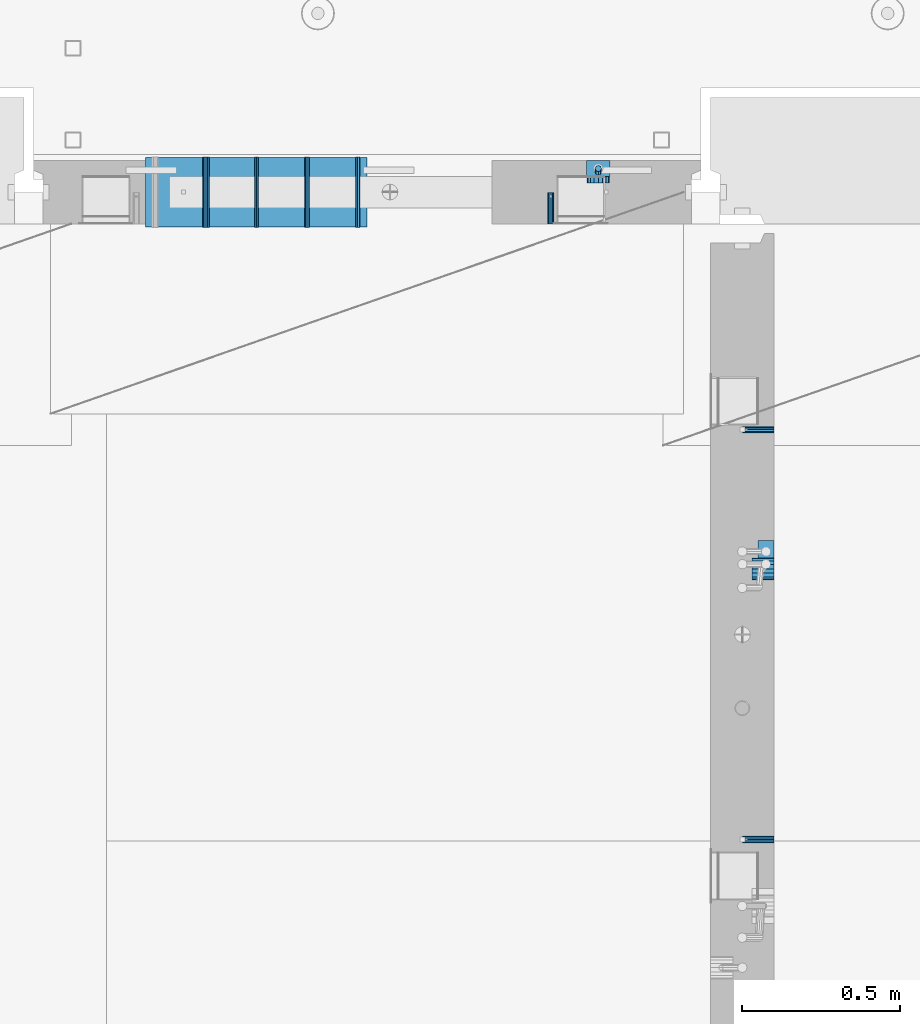
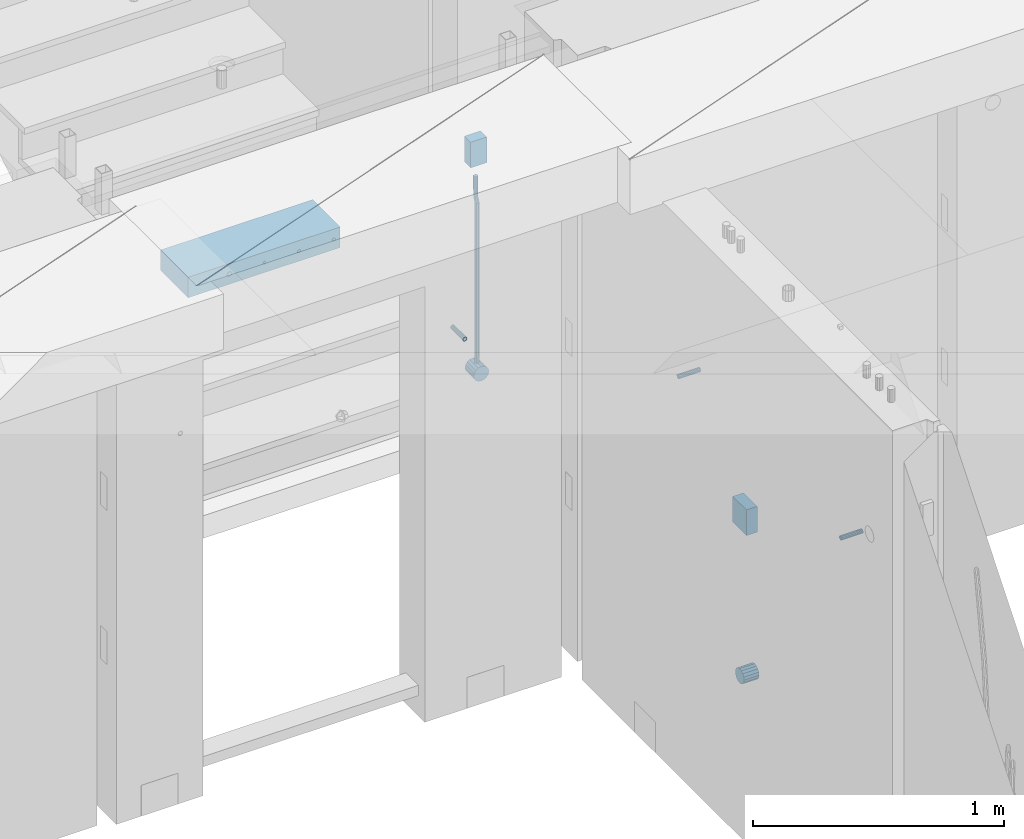
# One storey, part 149 of 350: 13 beams, 5 elements without a shape of their own.
"""IFC2X3 building model written with IfcOpenShell, lengths in millimetres."""

from ifc_helpers import new_model, si_unit, frame, origin_with_axes, place, context, subcontext, project, spatial, faceted_brep, material, type_object, element, aggregate, save


model = new_model("IFC2X3")

# Units and contexts
model_context = context("Model", 3, precision=1e-05, world=origin_with_axes())
body_context = subcontext(model_context, "Body", "Model", "MODEL_VIEW")
ifc_project = project(units=[si_unit("LENGTHUNIT", "METRE", prefix="MILLI"), si_unit("AREAUNIT", "SQUARE_METRE"), si_unit("VOLUMEUNIT", "CUBIC_METRE"), si_unit("MASSUNIT", "GRAM", prefix="KILO"), si_unit("TIMEUNIT", "SECOND"), si_unit("PLANEANGLEUNIT", "RADIAN"), si_unit("SOLIDANGLEUNIT", "STERADIAN"), si_unit("THERMODYNAMICTEMPERATUREUNIT", "DEGREE_CELSIUS"), si_unit("LUMINOUSINTENSITYUNIT", "LUMEN")], contexts=[model_context])

# Site, building, storey
site_placement = place(None, origin_with_axes())
site = spatial("IfcSite", under=ifc_project, at=site_placement, CompositionType="ELEMENT")
building_placement = place(site_placement, origin_with_axes())
building = spatial("IfcBuilding", under=site, at=building_placement, CompositionType="ELEMENT")
storey_placement = place(building_placement, origin_with_axes())
storey = spatial("IfcBuildingStorey", under=building, at=storey_placement, Name="2", CompositionType="ELEMENT", Elevation=0.0)

# Assemblies, beams
assembly_1_placement = place(storey_placement, origin_with_axes())
assembly_1 = element("IfcElementAssembly", 1, at=assembly_1_placement, inside=storey, AssemblyPlace="NOTDEFINED", PredefinedType="REINFORCEMENT_UNIT")
assembly_2_placement = place(assembly_1_placement, origin_with_axes())
assembly_2 = element("IfcElementAssembly", 2, at=assembly_2_placement, Name="Steel Assembly", AssemblyPlace="NOTDEFINED", PredefinedType="RIGID_FRAME")
ifc_material_1 = material(Name="STEEL/Steel_Undefined")
beam_type_1 = type_object("IfcBeamType", PredefinedType="NOTDEFINED")
beam_1_placement = place(assembly_2_placement, frame((21910.0, 13134.9999119588, 86555.0), z_axis=(0.0, -1.0, 0.0), x_axis=(-1.0, 3.00000001838171e-08, 0.0)))
beam_1 = element("IfcBeam", 3, at=beam_1_placement, type_object=beam_type_1, material=ifc_material_1, Name="M16", context=body_context, shape_type="Brep", body=[
    faceted_brep([(0.0, -8.49999999999272, -1.45519152283669e-11), (0.0, -7.36121593215648, 4.24999999998545), (100.000000000262, -7.36121593215648, 4.24999999998545), (100.000000000262, -8.49999999999272, -1.45519152283669e-11), (0.0, -4.24999999998545, 7.36121593216376), (100.000000000262, -4.24999999998545, 7.36121593216376), (0.0, 1.45519152283669e-11, 8.49999999998545), (100.000000000262, 1.45519152283669e-11, 8.49999999998545), (0.0, 4.25000000001455, 7.36121593216376), (100.000000000262, 4.25000000001455, 7.36121593216376), (0.0, 7.36121593217104, 4.24999999998545), (100.000000000262, 7.36121593217104, 4.24999999998545), (0.0, 8.50000000000728, 0.0), (100.000000000262, 8.50000000000728, 0.0), (0.0, 7.36121593217104, -4.25000000001455), (100.000000000262, 7.36121593217104, -4.25000000001455), (0.0, 4.25000000000728, -7.36121593219286), (100.000000000262, 4.25000000000728, -7.36121593219286), (0.0, 7.27595761418343e-12, -8.5), (100.000000000262, 7.27595761418343e-12, -8.5), (0.0, -4.24999999999272, -7.36121593217831), (100.000000000262, -4.24999999999272, -7.36121593217831), (0.0, -7.36121593215648, -4.25), (100.000000000262, -7.36121593215648, -4.25), (0.0, -10.4999999999927, -1.45519152283669e-11), (0.0, -9.09326673972828, -5.25000000001455), (100.000000000262, -9.09326673972828, -5.25000000001455), (100.000000000262, -10.4999999999927, -1.45519152283669e-11), (0.0, -5.24999999998545, -9.09326673974283), (100.000000000262, -5.24999999998545, -9.09326673974283), (0.0, 7.27595761418343e-12, -10.5), (100.000000000262, 7.27595761418343e-12, -10.5), (0.0, 5.25000000001455, -9.09326673975738), (100.000000000262, 5.25000000001455, -9.09326673975738), (0.0, 9.09326673975011, -5.25000000001455), (100.000000000262, 9.09326673975011, -5.25000000001455), (0.0, 10.5000000000073, -1.45519152283669e-11), (100.000000000262, 10.5000000000073, -1.45519152283669e-11), (0.0, 9.09326673975011, 5.25), (100.000000000262, 9.09326673975011, 5.25), (0.0, 5.25000000000728, 9.09326673972828), (100.000000000262, 5.25000000000728, 9.09326673972828), (0.0, 1.45519152283669e-11, 10.4999999999854), (100.000000000262, 1.45519152283669e-11, 10.4999999999854), (0.0, -5.24999999999272, 9.09326673972828), (100.000000000262, -5.24999999999272, 9.09326673972828), (0.0, -9.09326673972828, 5.24999999998545), (100.000000000262, -9.09326673972828, 5.24999999998545)], [[[0, 1, 2, 3]], [[1, 4, 5, 2]], [[4, 6, 7, 5]], [[6, 8, 9, 7]], [[8, 10, 11, 9]], [[10, 12, 13, 11]], [[12, 14, 15, 13]], [[14, 16, 17, 15]], [[16, 18, 19, 17]], [[18, 20, 21, 19]], [[20, 22, 23, 21]], [[22, 0, 3, 23]], [[24, 25, 26, 27]], [[25, 28, 29, 26]], [[28, 30, 31, 29]], [[30, 32, 33, 31]], [[32, 34, 35, 33]], [[34, 36, 37, 35]], [[36, 38, 39, 37]], [[38, 40, 41, 39]], [[40, 42, 43, 41]], [[42, 44, 45, 43]], [[44, 46, 47, 45]], [[46, 24, 27, 47]], [[29, 31, 33, 35, 37, 39, 41, 43, 45, 47, 27, 26], [5, 7, 9, 11, 13, 15, 17, 19, 21, 23, 3, 2]], [[46, 44, 42, 40, 38, 36, 34, 32, 30, 28, 25, 24], [22, 20, 18, 16, 14, 12, 10, 8, 6, 4, 1, 0]]]),
])
aggregate(assembly_2, [beam_1])
assembly_3_placement = place(assembly_1_placement, origin_with_axes())
assembly_3 = element("IfcElementAssembly", 4, at=assembly_3_placement, Name="Steel Assembly", AssemblyPlace="NOTDEFINED", PredefinedType="RIGID_FRAME")
beam_2_placement = place(assembly_3_placement, frame((21910.0, 14429.9999119589, 86555.0), z_axis=(0.0, 1.0, 0.0), x_axis=(-1.0, 3.00000001838171e-08, 0.0)))
beam_2 = element("IfcBeam", 5, at=beam_2_placement, type_object=beam_type_1, material=ifc_material_1, Name="M16", context=body_context, shape_type="Brep", body=[
    faceted_brep([(0.0, -8.49999999999272, -1.45519152283669e-11), (0.0, -7.36121593215648, 4.24999999998545), (100.000000000262, -7.36121593215648, 4.24999999998545), (100.000000000262, -8.49999999999272, -1.45519152283669e-11), (0.0, -4.24999999998545, 7.36121593216376), (100.000000000262, -4.24999999998545, 7.36121593216376), (0.0, 1.45519152283669e-11, 8.49999999998545), (100.000000000262, 1.45519152283669e-11, 8.49999999998545), (0.0, 4.25000000001455, 7.36121593216376), (100.000000000262, 4.25000000001455, 7.36121593216376), (0.0, 7.36121593217104, 4.24999999998545), (100.000000000262, 7.36121593217104, 4.24999999998545), (0.0, 8.50000000000728, 0.0), (100.000000000262, 8.50000000000728, 0.0), (0.0, 7.36121593217104, -4.25000000001455), (100.000000000262, 7.36121593217104, -4.25000000001455), (0.0, 4.25000000000728, -7.36121593219286), (100.000000000262, 4.25000000000728, -7.36121593219286), (0.0, 7.27595761418343e-12, -8.5), (100.000000000262, 7.27595761418343e-12, -8.5), (0.0, -4.24999999999272, -7.36121593217831), (100.000000000262, -4.24999999999272, -7.36121593217831), (0.0, -7.36121593215648, -4.25), (100.000000000262, -7.36121593215648, -4.25), (0.0, -10.4999999999927, -1.45519152283669e-11), (0.0, -9.09326673972828, -5.25000000001455), (100.000000000262, -9.09326673972828, -5.25000000001455), (100.000000000262, -10.4999999999927, -1.45519152283669e-11), (0.0, -5.24999999998545, -9.09326673974283), (100.000000000262, -5.24999999998545, -9.09326673974283), (0.0, 7.27595761418343e-12, -10.5), (100.000000000262, 7.27595761418343e-12, -10.5), (0.0, 5.25000000001455, -9.09326673975738), (100.000000000262, 5.25000000001455, -9.09326673975738), (0.0, 9.09326673975011, -5.25000000001455), (100.000000000262, 9.09326673975011, -5.25000000001455), (0.0, 10.5000000000073, -1.45519152283669e-11), (100.000000000262, 10.5000000000073, -1.45519152283669e-11), (0.0, 9.09326673975011, 5.25), (100.000000000262, 9.09326673975011, 5.25), (0.0, 5.25000000000728, 9.09326673972828), (100.000000000262, 5.25000000000728, 9.09326673972828), (0.0, 1.45519152283669e-11, 10.4999999999854), (100.000000000262, 1.45519152283669e-11, 10.4999999999854), (0.0, -5.24999999999272, 9.09326673972828), (100.000000000262, -5.24999999999272, 9.09326673972828), (0.0, -9.09326673972828, 5.24999999998545), (100.000000000262, -9.09326673972828, 5.24999999998545)], [[[0, 1, 2, 3]], [[1, 4, 5, 2]], [[4, 6, 7, 5]], [[6, 8, 9, 7]], [[8, 10, 11, 9]], [[10, 12, 13, 11]], [[12, 14, 15, 13]], [[14, 16, 17, 15]], [[16, 18, 19, 17]], [[18, 20, 21, 19]], [[20, 22, 23, 21]], [[22, 0, 3, 23]], [[24, 25, 26, 27]], [[25, 28, 29, 26]], [[28, 30, 31, 29]], [[30, 32, 33, 31]], [[32, 34, 35, 33]], [[34, 36, 37, 35]], [[36, 38, 39, 37]], [[38, 40, 41, 39]], [[40, 42, 43, 41]], [[42, 44, 45, 43]], [[44, 46, 47, 45]], [[46, 24, 27, 47]], [[29, 31, 33, 35, 37, 39, 41, 43, 45, 47, 27, 26], [5, 7, 9, 11, 13, 15, 17, 19, 21, 23, 3, 2]], [[46, 44, 42, 40, 38, 36, 34, 32, 30, 28, 25, 24], [22, 20, 18, 16, 14, 12, 10, 8, 6, 4, 1, 0]]]),
])
aggregate(assembly_3, [beam_2])

assembly_4_placement = place(storey_placement, origin_with_axes())
assembly_4 = element("IfcElementAssembly", 6, at=assembly_4_placement, inside=storey, AssemblyPlace="NOTDEFINED", PredefinedType="REINFORCEMENT_UNIT")
assembly_5_placement = place(assembly_4_placement, origin_with_axes())
assembly_5 = element("IfcElementAssembly", 7, at=assembly_5_placement, Name="Steel Assembly", AssemblyPlace="NOTDEFINED", PredefinedType="RIGID_FRAME")
beam_3_placement = place(assembly_5_placement, frame((21205.004085231, 15080.0, 86555.0), z_axis=(1.0, 0.0, 0.0), x_axis=(0.0, 1.0, 0.0)))
beam_3 = element("IfcBeam", 8, at=beam_3_placement, type_object=beam_type_1, material=ifc_material_1, Name="M16", context=body_context, shape_type="Brep", body=[
    faceted_brep([(0.0, -8.49999999999272, -1.45519152283669e-11), (0.0, -7.36121593215648, 4.24999999998545), (100.000000000262, -7.36121593215648, 4.24999999998545), (100.000000000262, -8.49999999999272, -1.45519152283669e-11), (0.0, -4.24999999998545, 7.36121593216376), (100.000000000262, -4.24999999998545, 7.36121593216376), (0.0, 1.45519152283669e-11, 8.49999999998545), (100.000000000262, 1.45519152283669e-11, 8.49999999998545), (0.0, 4.25000000001455, 7.36121593216376), (100.000000000262, 4.25000000001455, 7.36121593216376), (0.0, 7.36121593217104, 4.24999999998545), (100.000000000262, 7.36121593217104, 4.24999999998545), (0.0, 8.50000000000728, 0.0), (100.000000000262, 8.50000000000728, 0.0), (0.0, 7.36121593217104, -4.25000000001455), (100.000000000262, 7.36121593217104, -4.25000000001455), (0.0, 4.25000000000728, -7.36121593219286), (100.000000000262, 4.25000000000728, -7.36121593219286), (0.0, 7.27595761418343e-12, -8.5), (100.000000000262, 7.27595761418343e-12, -8.5), (0.0, -4.24999999999272, -7.36121593217831), (100.000000000262, -4.24999999999272, -7.36121593217831), (0.0, -7.36121593215648, -4.25), (100.000000000262, -7.36121593215648, -4.25), (0.0, -10.4999999999927, -1.45519152283669e-11), (0.0, -9.09326673972828, -5.25000000001455), (100.000000000262, -9.09326673972828, -5.25000000001455), (100.000000000262, -10.4999999999927, -1.45519152283669e-11), (0.0, -5.24999999998545, -9.09326673974283), (100.000000000262, -5.24999999998545, -9.09326673974283), (0.0, 7.27595761418343e-12, -10.5), (100.000000000262, 7.27595761418343e-12, -10.5), (0.0, 5.25000000001455, -9.09326673975738), (100.000000000262, 5.25000000001455, -9.09326673975738), (0.0, 9.09326673975011, -5.25000000001455), (100.000000000262, 9.09326673975011, -5.25000000001455), (0.0, 10.5000000000073, -1.45519152283669e-11), (100.000000000262, 10.5000000000073, -1.45519152283669e-11), (0.0, 9.09326673975011, 5.25), (100.000000000262, 9.09326673975011, 5.25), (0.0, 5.25000000000728, 9.09326673972828), (100.000000000262, 5.25000000000728, 9.09326673972828), (0.0, 1.45519152283669e-11, 10.4999999999854), (100.000000000262, 1.45519152283669e-11, 10.4999999999854), (0.0, -5.24999999999272, 9.09326673972828), (100.000000000262, -5.24999999999272, 9.09326673972828), (0.0, -9.09326673972828, 5.24999999998545), (100.000000000262, -9.09326673972828, 5.24999999998545)], [[[0, 1, 2, 3]], [[1, 4, 5, 2]], [[4, 6, 7, 5]], [[6, 8, 9, 7]], [[8, 10, 11, 9]], [[10, 12, 13, 11]], [[12, 14, 15, 13]], [[14, 16, 17, 15]], [[16, 18, 19, 17]], [[18, 20, 21, 19]], [[20, 22, 23, 21]], [[22, 0, 3, 23]], [[24, 25, 26, 27]], [[25, 28, 29, 26]], [[28, 30, 31, 29]], [[30, 32, 33, 31]], [[32, 34, 35, 33]], [[34, 36, 37, 35]], [[36, 38, 39, 37]], [[38, 40, 41, 39]], [[40, 42, 43, 41]], [[42, 44, 45, 43]], [[44, 46, 47, 45]], [[46, 24, 27, 47]], [[29, 31, 33, 35, 37, 39, 41, 43, 45, 47, 27, 26], [5, 7, 9, 11, 13, 15, 17, 19, 21, 23, 3, 2]], [[46, 44, 42, 40, 38, 36, 34, 32, 30, 28, 25, 24], [22, 20, 18, 16, 14, 12, 10, 8, 6, 4, 1, 0]]]),
])
aggregate(assembly_5, [beam_3])
ifc_material_2 = material()
beam_type_2 = type_object("IfcBeamType", Name="D20", PredefinedType="NOTDEFINED")
beam_4_placement = place(assembly_4_placement, frame((21354.9999999958, 15245.0000022759, 86290.0), z_axis=(0.00020576299992186, -0.999642804629538, -0.0267249099901004), x_axis=(-4.30000201928125e-08, -0.0267249099948059, 0.999642825806181)))
beam_4 = element("IfcBeam", 9, at=beam_4_placement, type_object=beam_type_2, material=ifc_material_2, Name="JM20", ObjectType="D20", context=body_context, shape_type="Brep", body=[
    faceted_brep([(0.0, -10.0, 0.0), (-4.19531716033816e-08, -7.07106781186667, -7.07106781187031), (60.3581158964225, -7.07106779467358, -7.07106780560207), (60.3581159005553, -9.99999998281055, 6.26459950581193e-09), (0.0, 0.0, -10.0), (60.3581158930319, 1.71930878423154e-08, -9.9999999937354), (4.196772351861e-08, 7.07106781186303, -7.07106781186667), (60.3581158923917, 7.07106782905612, -7.07106780560207), (0.0, 10.0, 0.0), (60.3581158948509, 10.0000000171895, 6.26459950581193e-09), (4.196772351861e-08, 7.07106781185939, 7.07106781185939), (60.3581158989837, 7.07106782905612, 7.07106781813127), (0.0, 0.0, 10.0), (60.3581159023597, 1.71930878423154e-08, 10.0000000062646), (-4.19531716033816e-08, -7.07106781187031, 7.07106781185939), (60.358115903, -7.07106779467722, 7.07106781813127), (60.8972477222414, -7.07106779452079, -7.07106780554386), (60.991799419251, -9.99999998403655, 6.21366780251265e-09), (60.8581158930319, 1.7334969015792e-08, -9.99999999368447), (60.8972861483926, 7.07106782920528, -7.07106780554386), (60.9917724058905, 10.0000000159635, 6.21366780251265e-09), (61.0863241029147, 7.07106782926348, 7.07106781820403), (61.1254559321096, 1.7415004549548e-08, 10.0000000063446), (61.086285676749, -7.07106779446985, 7.07106781820403), (61.4361869218264, -7.07107072394501, -7.08547838249069), (61.6251751877571, -10.0000034255863, -0.0169367769813107), (61.35793724822, -2.69946758635342e-06, -10.0133646071736), (61.4362637644808, 7.07106489957732, -7.08547940969947), (61.6252838596702, 9.99999657411536, -0.0169382296771801), (61.8142721256008, 7.07106387247404, 7.0516033758322), (61.8925217992073, -4.15200702263974e-06, 9.97948960051872), (61.814195282961, -7.07107175104829, 7.05160440304098), (775.690073058257, -7.07495307777208, -26.1837562433175), (775.879061324187, -10.0038857794134, -19.1152146378081), (775.611823384636, -0.00388505329101463, -29.1116424680004), (775.690149900896, 7.06718254575026, -26.1837572705263), (775.8791699961, 9.99611422029193, -19.1152160905003), (776.068158262031, 7.06718151865061, -12.0466744849909), (776.146407935637, -0.00388650583045091, -9.11878826030807), (776.068081419377, -7.07495410487172, -12.0466734577822), (776.844979390982, -7.07495935530824, -26.2146370302071), (778.703176670489, -10.0039011299996, -19.1907280380728), (776.111644739809, -0.00388777008629404, -29.1250070814895), (776.932750209904, 7.0671757915552, -26.2169828873994), (778.827303353013, 9.99609819560283, -19.1940455811236), (780.685500632535, 7.06715642091513, -12.1701365889894), (781.418835283708, -0.00391516431045602, -9.25976653770704), (780.597729813613, -7.07497872594467, -12.1677907318008), (777.861329320964, -7.08852484077215, -26.7638283058368), (781.188477298943, -10.0370730804789, -20.5336763496562), (776.551501535956, -0.00975865254440578, -29.362686553719), (778.026273295982, 7.05258025600779, -26.8078751783723), (781.421743305415, 9.96146953432981, -20.595968034173), (784.74889128338, 7.01292129462308, -14.3658160779887), (786.058719068402, -0.0658448936046625, -11.7669578301065), (784.583947308391, -7.12818380215685, -14.3217692054532), (795.432392943592, -7.32305037289916, -36.2584664814858), (798.759540921557, -10.2715986126059, -30.0283145252979), (794.12256515857, -0.244284184671415, -38.8573247293643), (795.597336918581, 6.81805472388078, -36.3025133540177), (798.992806928029, 9.72694400219916, -30.0906062098184), (802.319954905994, 6.77839576249244, -23.8604542536341), (803.629782691016, -0.300370425735309, -21.2615960057519), (802.15501093099, -7.3627093342875, -23.8164073811022), (799.505846831846, -7.3774198158244, -38.4595837060842), (801.367995818946, -10.3064143349802, -31.4378100447575), (798.762755292832, -0.306218002893729, -41.3646815597422), (799.574014147365, 6.7649769840682, -38.4513366830724), (801.464398961049, 9.69395502388943, -31.4261469929661), (803.32654794812, 6.76496050473361, -24.4043733316357), (804.069639487148, -0.306241308189783, -21.4992754779851), (803.258380632629, -7.37743629515535, -24.4126203546512), (804.134608044958, -7.36363999659807, -38.5831936197719), (804.332044311042, -10.2975903644801, -31.5169642204455), (804.035512197443, -0.290521008897485, -41.5054892177468), (804.092805771987, 6.77842942390271, -38.5720098863276), (804.272926969657, 9.70231601001069, -31.5011480329304), (804.470363235741, 6.76836564212863, -24.434918633604), (804.569459083272, -0.304753345568315, -21.5126230356327), (804.512165508728, -7.37370377836123, -24.4461023670447), (901.742523775247, -7.07306129268909, -41.1897886639781), (901.939960041316, -10.0070116605639, -34.1235592646481), (901.643427927731, 5.76950078539085e-05, -44.1120842619457), (901.700721502275, 7.06900812780805, -41.1786049305338), (901.880842699946, 9.99289471391967, -34.1077430771329), (902.07827896603, 7.05894434603761, -27.0415136778065), (902.177374813546, -0.0141746416556998, -24.1192180798353), (902.120081238987, -7.08312507445589, -27.0526974112508)], [[[0, 1, 2, 3]], [[1, 4, 5, 2]], [[4, 6, 7, 5]], [[6, 8, 9, 7]], [[8, 10, 11, 9]], [[10, 12, 13, 11]], [[12, 14, 15, 13]], [[14, 0, 3, 15]], [[14, 12, 10, 8, 6, 4, 1, 0]], [[3, 2, 16, 17]], [[2, 5, 18, 16]], [[5, 7, 19, 18]], [[7, 9, 20, 19]], [[9, 11, 21, 20]], [[11, 13, 22, 21]], [[13, 15, 23, 22]], [[15, 3, 17, 23]], [[17, 16, 24, 25]], [[16, 18, 26, 24]], [[18, 19, 27, 26]], [[19, 20, 28, 27]], [[20, 21, 29, 28]], [[21, 22, 30, 29]], [[22, 23, 31, 30]], [[23, 17, 25, 31]], [[25, 24, 32, 33]], [[24, 26, 34, 32]], [[26, 27, 35, 34]], [[27, 28, 36, 35]], [[28, 29, 37, 36]], [[29, 30, 38, 37]], [[30, 31, 39, 38]], [[31, 25, 33, 39]], [[33, 32, 40, 41]], [[32, 34, 42, 40]], [[34, 35, 43, 42]], [[35, 36, 44, 43]], [[36, 37, 45, 44]], [[37, 38, 46, 45]], [[38, 39, 47, 46]], [[39, 33, 41, 47]], [[41, 40, 48, 49]], [[40, 42, 50, 48]], [[42, 43, 51, 50]], [[43, 44, 52, 51]], [[44, 45, 53, 52]], [[45, 46, 54, 53]], [[46, 47, 55, 54]], [[47, 41, 49, 55]], [[49, 48, 56, 57]], [[48, 50, 58, 56]], [[50, 51, 59, 58]], [[51, 52, 60, 59]], [[52, 53, 61, 60]], [[53, 54, 62, 61]], [[54, 55, 63, 62]], [[55, 49, 57, 63]], [[57, 56, 64, 65]], [[56, 58, 66, 64]], [[58, 59, 67, 66]], [[59, 60, 68, 67]], [[60, 61, 69, 68]], [[61, 62, 70, 69]], [[62, 63, 71, 70]], [[63, 57, 65, 71]], [[65, 64, 72, 73]], [[64, 66, 74, 72]], [[66, 67, 75, 74]], [[67, 68, 76, 75]], [[68, 69, 77, 76]], [[69, 70, 78, 77]], [[70, 71, 79, 78]], [[71, 65, 73, 79]], [[73, 72, 80, 81]], [[72, 74, 82, 80]], [[74, 75, 83, 82]], [[75, 76, 84, 83]], [[76, 77, 85, 84]], [[77, 78, 86, 85]], [[78, 79, 87, 86]], [[79, 73, 81, 87]], [[82, 83, 84, 85, 86, 87, 81, 80]]]),
])

# Beam
beam_type_3 = type_object("IfcBeamType", Name="D70", PredefinedType="NOTDEFINED")
beam_5_placement = place(assembly_1_placement, frame((21910.0000022791, 13990.0, 85355.0), z_axis=(0.0, 0.0, 1.0), x_axis=(-1.0, 3.00000001838171e-08, 0.0)))
beam_5 = element("IfcBeam", 10, at=beam_5_placement, type_object=beam_type_3, material=ifc_material_2, ObjectType="D70", context=body_context, shape_type="Brep", body=[
    faceted_brep([(0.0, -35.0, 0.0), (0.0, -32.3357836378964, -13.3939201327739), (70.0, -32.3357836378964, -13.3939201327739), (70.0, -35.0, 0.0), (0.0, -24.7487373415279, -24.7487373415352), (70.0, -24.7487373415279, -24.7487373415352), (0.0, -13.3939201327776, -32.3357836379), (70.0, -13.3939201327776, -32.3357836379), (0.0, 0.0, -35.0), (70.0, 0.0, -35.0), (0.0, 13.3939201327776, -32.3357836379), (70.0, 13.3939201327776, -32.3357836379), (0.0, 24.7487373415279, -24.7487373415352), (70.0, 24.7487373415279, -24.7487373415352), (0.0, 32.3357836378964, -13.3939201327739), (70.0, 32.3357836378964, -13.3939201327739), (0.0, 35.0, 0.0), (70.0, 35.0, 0.0), (0.0, 32.3357836378964, 13.3939201327739), (70.0, 32.3357836378964, 13.3939201327739), (0.0, 24.7487373415279, 24.7487373415352), (70.0, 24.7487373415279, 24.7487373415352), (0.0, 13.3939201327776, 32.3357836379), (70.0, 13.3939201327776, 32.3357836379), (0.0, 0.0, 35.0), (70.0, 0.0, 35.0), (0.0, -13.3939201327776, 32.3357836379), (70.0, -13.3939201327776, 32.3357836379), (0.0, -24.7487373415279, 24.7487373415352), (70.0, -24.7487373415279, 24.7487373415352), (0.0, -32.3357836378964, 13.3939201327739), (70.0, -32.3357836378964, 13.3939201327739)], [[[0, 1, 2, 3]], [[1, 4, 5, 2]], [[4, 6, 7, 5]], [[6, 8, 9, 7]], [[8, 10, 11, 9]], [[10, 12, 13, 11]], [[12, 14, 15, 13]], [[14, 16, 17, 15]], [[16, 18, 19, 17]], [[18, 20, 21, 19]], [[20, 22, 23, 21]], [[22, 24, 25, 23]], [[24, 26, 27, 25]], [[26, 28, 29, 27]], [[28, 30, 31, 29]], [[30, 0, 3, 31]], [[5, 7, 9, 11, 13, 15, 17, 19, 21, 23, 25, 27, 29, 31, 3, 2]], [[30, 28, 26, 24, 22, 20, 18, 16, 14, 12, 10, 8, 6, 4, 1, 0]]]),
])

beam_6_placement = place(assembly_4_placement, frame((21354.9999999996, 15280.0000022759, 86255.0), z_axis=(0.0, 0.0, 1.0), x_axis=(0.0, -1.0, 0.0)))
beam_6 = element("IfcBeam", 11, at=beam_6_placement, type_object=beam_type_3, material=ifc_material_2, ObjectType="D70", context=body_context, shape_type="Brep", body=[
    faceted_brep([(0.0, -35.0, 0.0), (0.0, -32.3357836378964, -13.3939201327739), (70.0, -32.3357836378964, -13.3939201327739), (70.0, -35.0, 0.0), (0.0, -24.7487373415279, -24.7487373415352), (70.0, -24.7487373415279, -24.7487373415352), (0.0, -13.3939201327776, -32.3357836379), (70.0, -13.3939201327776, -32.3357836379), (0.0, 0.0, -35.0), (70.0, 0.0, -35.0), (0.0, 13.3939201327776, -32.3357836379), (70.0, 13.3939201327776, -32.3357836379), (0.0, 24.7487373415279, -24.7487373415352), (70.0, 24.7487373415279, -24.7487373415352), (0.0, 32.3357836378964, -13.3939201327739), (70.0, 32.3357836378964, -13.3939201327739), (0.0, 35.0, 0.0), (70.0, 35.0, 0.0), (0.0, 32.3357836378964, 13.3939201327739), (70.0, 32.3357836378964, 13.3939201327739), (0.0, 24.7487373415279, 24.7487373415352), (70.0, 24.7487373415279, 24.7487373415352), (0.0, 13.3939201327776, 32.3357836379), (70.0, 13.3939201327776, 32.3357836379), (0.0, 0.0, 35.0), (70.0, 0.0, 35.0), (0.0, -13.3939201327776, 32.3357836379), (70.0, -13.3939201327776, 32.3357836379), (0.0, -24.7487373415279, 24.7487373415352), (70.0, -24.7487373415279, 24.7487373415352), (0.0, -32.3357836378964, 13.3939201327739), (70.0, -32.3357836378964, 13.3939201327739)], [[[0, 1, 2, 3]], [[1, 4, 5, 2]], [[4, 6, 7, 5]], [[6, 8, 9, 7]], [[8, 10, 11, 9]], [[10, 12, 13, 11]], [[12, 14, 15, 13]], [[14, 16, 17, 15]], [[16, 18, 19, 17]], [[18, 20, 21, 19]], [[20, 22, 23, 21]], [[22, 24, 25, 23]], [[24, 26, 27, 25]], [[26, 28, 29, 27]], [[28, 30, 31, 29]], [[30, 0, 3, 31]], [[5, 7, 9, 11, 13, 15, 17, 19, 21, 23, 25, 27, 29, 31, 3, 2]], [[30, 28, 26, 24, 22, 20, 18, 16, 14, 12, 10, 8, 6, 4, 1, 0]]]),
])

ifc_material_3 = material()
beam_type_4 = type_object("IfcBeamType", Name="D12", PredefinedType="NOTDEFINED")
beam_7_placement = place(assembly_4_placement, frame((20274.9991455079, 15068.9997314798, 87260.0), z_axis=(-1.0, 3.00000001838171e-08, 0.0), x_axis=(0.0, 1.0, 0.0)))
beam_7 = element("IfcBeam", 12, at=beam_7_placement, type_object=beam_type_4, material=ifc_material_3, Name="12", ObjectType="D12", context=body_context, shape_type="Brep", body=[
    faceted_brep([(0.0, -6.0, -1.45519152283669e-11), (0.0, -4.24264068712, -4.24264068713819), (222.000077784061, -4.24264068712364, -4.24264068712), (222.000077784061, -6.0, 0.0), (3.63797880709171e-12, 0.0, -6.0000000000291), (222.000077784061, 0.0, -6.0), (0.0, 4.24264068712, -4.24264068713819), (222.000077784061, 4.24264068712364, -4.24264068712), (0.0, 6.0, -1.45519152283669e-11), (222.000077784061, 6.0, 0.0), (0.0, 4.24264068712, 4.24264068709454), (222.000077784061, 4.24264068712364, 4.24264068712), (0.0, 0.0, 5.99999999998545), (222.000077784061, 0.0, 6.0), (0.0, -4.24264068712, 4.24264068709454), (222.000077784061, -4.24264068712364, 4.24264068712)], [[[0, 1, 2, 3]], [[1, 4, 5, 2]], [[4, 6, 7, 5]], [[6, 8, 9, 7]], [[8, 10, 11, 9]], [[10, 12, 13, 11]], [[12, 14, 15, 13]], [[14, 0, 3, 15]], [[5, 7, 9, 11, 13, 15, 3, 2]], [[14, 12, 10, 8, 6, 4, 1, 0]]]),
])

beam_type_5 = type_object("IfcBeamType", Name="D15", PredefinedType="NOTDEFINED")
beam_8_placement = place(assembly_4_placement, frame((20594.99899292, 15068.9997314793, 87260.0), z_axis=(-1.0, 3.00000001838171e-08, 0.0), x_axis=(0.0, 1.0, 0.0)))
beam_8 = element("IfcBeam", 13, at=beam_8_placement, type_object=beam_type_5, material=ifc_material_3, Name="15", ObjectType="D15", context=body_context, shape_type="Brep", body=[
    faceted_brep([(0.0, -7.5, 0.0), (0.0, -5.30330085889727, -5.30330085890091), (222.000077784061, -5.30330085889727, -5.30330085890091), (222.000077784061, -7.5, 0.0), (0.0, 1.45519152283669e-11, -7.5), (222.000077784061, 0.0, -7.5), (0.0, 5.30330085889727, -5.30330085890091), (222.000077784061, 5.30330085889727, -5.30330085890091), (0.0, 7.5, 0.0), (222.000077784061, 7.5, 0.0), (0.0, 5.30330085889727, 5.30330085890091), (222.000077784061, 5.30330085889727, 5.30330085890091), (0.0, 1.45519152283669e-11, 7.5), (222.000077784061, 0.0, 7.5), (0.0, -5.30330085889727, 5.30330085890091), (222.000077784061, -5.30330085889727, 5.30330085890091)], [[[0, 1, 2, 3]], [[1, 4, 5, 2]], [[4, 6, 7, 5]], [[6, 8, 9, 7]], [[8, 10, 11, 9]], [[10, 12, 13, 11]], [[12, 14, 15, 13]], [[14, 0, 3, 15]], [[5, 7, 9, 11, 13, 15, 3, 2]], [[14, 12, 10, 8, 6, 4, 1, 0]]]),
])

beam_9_placement = place(assembly_4_placement, frame((20434.9991455079, 15068.9997314796, 87260.0), z_axis=(-1.0, 3.00000001838171e-08, 0.0), x_axis=(0.0, 1.0, 0.0)))
beam_9 = element("IfcBeam", 14, at=beam_9_placement, type_object=beam_type_5, material=ifc_material_3, Name="15", ObjectType="D15", context=body_context, shape_type="Brep", body=[
    faceted_brep([(0.0, -7.5, 0.0), (0.0, -5.30330085889727, -5.30330085890091), (222.000077784061, -5.30330085889727, -5.30330085890091), (222.000077784061, -7.5, 0.0), (0.0, 1.45519152283669e-11, -7.5), (222.000077784061, 0.0, -7.5), (0.0, 5.30330085889727, -5.30330085890091), (222.000077784061, 5.30330085889727, -5.30330085890091), (0.0, 7.5, 0.0), (222.000077784061, 7.5, 0.0), (0.0, 5.30330085889727, 5.30330085890091), (222.000077784061, 5.30330085889727, 5.30330085890091), (0.0, 1.45519152283669e-11, 7.5), (222.000077784061, 0.0, 7.5), (0.0, -5.30330085889727, 5.30330085890091), (222.000077784061, -5.30330085889727, 5.30330085890091)], [[[0, 1, 2, 3]], [[1, 4, 5, 2]], [[4, 6, 7, 5]], [[6, 8, 9, 7]], [[8, 10, 11, 9]], [[10, 12, 13, 11]], [[12, 14, 15, 13]], [[14, 0, 3, 15]], [[5, 7, 9, 11, 13, 15, 3, 2]], [[14, 12, 10, 8, 6, 4, 1, 0]]]),
])

beam_type_6 = type_object("IfcBeamType", Name="D22", PredefinedType="NOTDEFINED")
beam_10_placement = place(assembly_4_placement, frame((20114.9991455079, 15068.9997314801, 87260.0), z_axis=(-1.0, 3.00000001838171e-08, 0.0), x_axis=(0.0, 1.0, 0.0)))
beam_10 = element("IfcBeam", 15, at=beam_10_placement, type_object=beam_type_6, material=ifc_material_3, Name="22", ObjectType="D22", context=body_context, shape_type="Brep", body=[
    faceted_brep([(0.0, -11.0, 0.0), (0.0, -9.52627944163396, -5.5), (222.000077784061, -9.52627944163396, -5.5), (222.000077784061, -11.0, 0.0), (0.0, -5.5, -9.52627944163032), (222.000077784061, -5.5, -9.52627944163032), (0.0, 0.0, -11.0), (222.000077784061, 0.0, -11.0), (0.0, 5.5, -9.52627944163032), (222.000077784061, 5.5, -9.52627944163032), (0.0, 9.52627944163396, -5.5), (222.000077784061, 9.52627944163396, -5.5), (0.0, 11.0, 0.0), (222.000077784061, 11.0, 0.0), (0.0, 9.52627944163396, 5.5), (222.000077784061, 9.52627944163396, 5.5), (0.0, 5.5, 9.52627944163032), (222.000077784061, 5.5, 9.52627944163032), (0.0, 0.0, 11.0), (222.000077784061, 0.0, 11.0), (0.0, -5.5, 9.52627944163032), (222.000077784061, -5.5, 9.52627944163032), (0.0, -9.52627944163396, 5.5), (222.000077784061, -9.52627944163396, 5.5)], [[[0, 1, 2, 3]], [[1, 4, 5, 2]], [[4, 6, 7, 5]], [[6, 8, 9, 7]], [[8, 10, 11, 9]], [[10, 12, 13, 11]], [[12, 14, 15, 13]], [[14, 16, 17, 15]], [[16, 18, 19, 17]], [[18, 20, 21, 19]], [[20, 22, 23, 21]], [[22, 0, 3, 23]], [[5, 7, 9, 11, 13, 15, 17, 19, 21, 23, 3, 2]], [[22, 20, 18, 16, 14, 12, 10, 8, 6, 4, 1, 0]]]),
])

beam_type_7 = type_object("IfcBeamType", PredefinedType="NOTDEFINED")
beam_11_placement = place(assembly_4_placement, frame((20274.9991455078, 15069.9997314811, 87260.0), z_axis=(-1.0, 3.00000001838171e-08, 0.0), x_axis=(0.0, 1.0, 0.0)))
beam_11 = element("IfcBeam", 16, at=beam_11_placement, type_object=beam_type_7, material=ifc_material_3, context=body_context, shape_type="Brep", body=[
    faceted_brep([(0.0, 50.0, -350.0), (0.0, 50.0, 350.0), (220.000077784061, 50.0, 350.0), (220.000077784061, 50.0, -350.0), (0.0, -50.0, 350.0), (220.000077784061, -50.0, 350.0), (0.0, -50.0, -350.0), (220.000077784061, -50.0, -350.0)], [[[0, 1, 2, 3]], [[1, 4, 5, 2]], [[4, 6, 7, 5]], [[6, 0, 3, 7]], [[5, 7, 3, 2]], [[6, 4, 1, 0]]]),
])

beam_type_8 = type_object("IfcBeamType", Name="125X50", PredefinedType="NOTDEFINED")
beam_12_placement = place(assembly_1_placement, frame((21885.0, 13970.0, 86105.0), z_axis=(0.0, 0.0, 1.0), x_axis=(0.0, 1.0, 0.0)))
beam_12 = element("IfcBeam", 17, at=beam_12_placement, type_object=beam_type_8, material=ifc_material_2, Name="WM2", ObjectType="125X50", context=body_context, shape_type="Brep", body=[
    faceted_brep([(0.0, 25.0, -62.5), (0.0, 25.0, 62.5), (110.0, 25.0, 62.5), (110.0, 25.0, -62.5), (0.0, -25.0, 62.5), (110.0, -25.0, 62.5), (0.0, -25.0, -62.5), (110.0, -25.0, -62.5)], [[[0, 1, 2, 3]], [[1, 4, 5, 2]], [[4, 6, 7, 5]], [[6, 0, 3, 7]], [[5, 7, 3, 2]], [[0, 6, 4, 1]]]),
])

aggregate(assembly_1, [assembly_2, assembly_3, beam_12, beam_5])

beam_13_placement = place(assembly_4_placement, frame((21392.4999999996, 15254.9999999967, 87320.0), z_axis=(0.0, 0.0, 1.0), x_axis=(-1.0, 3.00000001838171e-08, 0.0)))
beam_13 = element("IfcBeam", 18, at=beam_13_placement, type_object=beam_type_8, material=ifc_material_2, Name="WM1", ObjectType="125X50", context=body_context, shape_type="Brep", body=[
    faceted_brep([(0.0, 25.0, -62.5), (0.0, 25.0, 62.5), (75.0, 25.0, 62.5), (75.0, 25.0, -62.5), (0.0, -25.0, 62.5), (75.0, -25.0, 62.5), (0.0, -25.0, -62.5), (75.0, -25.0, -62.5)], [[[0, 1, 2, 3]], [[1, 4, 5, 2]], [[4, 6, 7, 5]], [[6, 0, 3, 7]], [[5, 7, 3, 2]], [[0, 6, 4, 1]]]),
])

aggregate(assembly_4, [assembly_5, beam_13, beam_4, beam_6, beam_10, beam_7, beam_11, beam_8, beam_9])

save(model, "model.ifc")
